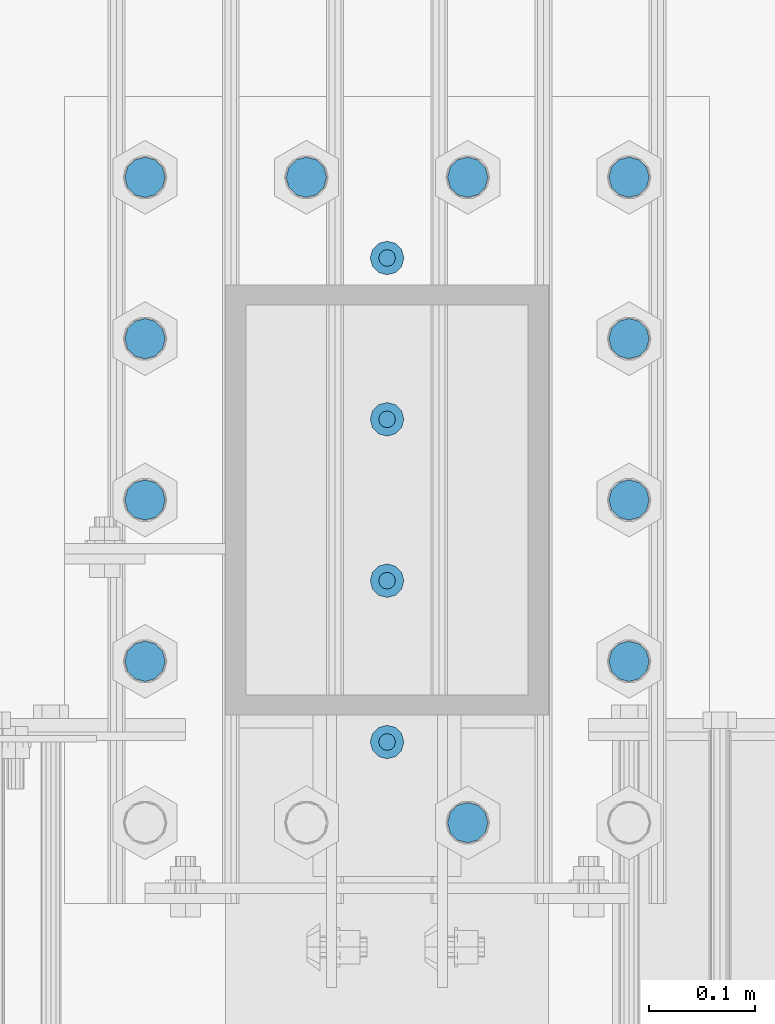
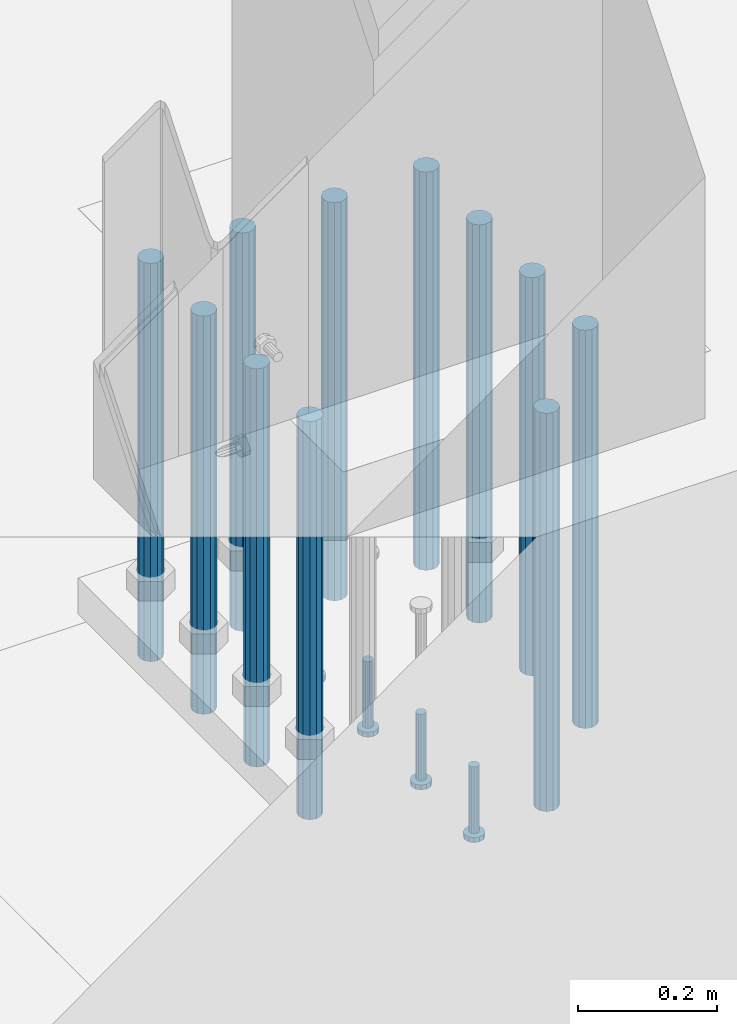
# One storey, part 1086 of 1876: 15 beams, 1 element without a shape of its own.
"""IFC2X3 building model written with IfcOpenShell, lengths in millimetres."""

from ifc_helpers import new_model, si_unit, frame, origin_with_axes, place, context, subcontext, project, spatial, faceted_brep, material, type_object, element, aggregate, save


model = new_model("IFC2X3")

# Units and contexts
model_context = context("Model", 3, precision=1e-05, world=origin_with_axes())
body_context = subcontext(model_context, "Body", "Model", "MODEL_VIEW")
ifc_project = project(units=[si_unit("LENGTHUNIT", "METRE", prefix="MILLI"), si_unit("AREAUNIT", "SQUARE_METRE"), si_unit("VOLUMEUNIT", "CUBIC_METRE"), si_unit("MASSUNIT", "GRAM", prefix="KILO"), si_unit("TIMEUNIT", "SECOND"), si_unit("PLANEANGLEUNIT", "RADIAN"), si_unit("SOLIDANGLEUNIT", "STERADIAN"), si_unit("THERMODYNAMICTEMPERATUREUNIT", "DEGREE_CELSIUS"), si_unit("LUMINOUSINTENSITYUNIT", "LUMEN")], contexts=[model_context])

# Site, building, storey
site_placement = place(None, origin_with_axes())
site = spatial("IfcSite", under=ifc_project, at=site_placement, CompositionType="ELEMENT")
building_placement = place(site_placement, origin_with_axes())
building = spatial("IfcBuilding", under=site, at=building_placement, Name="Undefined", CompositionType="ELEMENT")
storey_placement = place(building_placement, origin_with_axes())
storey = spatial("IfcBuildingStorey", under=building, at=storey_placement, Name="Undefined", CompositionType="ELEMENT", Elevation=0.0)

# Assembly, beams
assembly_placement = place(storey_placement, origin_with_axes())
assembly = element("IfcElementAssembly", 1, at=assembly_placement, inside=storey, Name="PLATE", AssemblyPlace="NOTDEFINED", PredefinedType="RIGID_FRAME")
ifc_material_1 = material(Name="STEEL/F1554-55, S1")
beam_type_1 = type_object("IfcBeamType", PredefinedType="NOTDEFINED")
beam_1_placement = place(assembly_placement, frame((3660.77500610347, -25552.4000091553, -63.4999999999993), z_axis=(-1.0, 0.0, 0.0), x_axis=(0.0, 0.0, -1.0)))
beam_1 = element("IfcBeam", 2, at=beam_1_placement, type_object=beam_type_1, material=ifc_material_1, Name="WELDED ANCHORS", context=body_context, shape_type="Brep", body=[
    faceted_brep([(0.0, -19.0500000000002, 0.0), (0.0, -16.4977839420935, -9.52500000000146), (698.499999999999, -16.4977839420935, -9.52499999999964), (698.499999999999, -19.0499999999993, 0.0), (0.0, -9.52500000000009, -16.4977839420935), (698.499999999999, -9.52500000000146, -16.4977839420935), (0.0, 0.0, -19.05), (698.499999999999, 0.0, -19.0500000000002), (0.0, 9.52500000000009, -16.4977839420935), (698.499999999999, 9.52500000000146, -16.4977839420935), (0.0, 16.4977839420935, -9.52500000000146), (698.499999999999, 16.4977839420935, -9.52499999999964), (-9.09494701772928e-13, 19.05, -1.81898940354586e-12), (698.499999999999, 19.0499999999993, 0.0), (0.0, 16.4977839420935, 9.52500000000146), (698.499999999999, 16.4977839420935, 9.52499999999964), (0.0, 9.52500000000009, 16.4977839420935), (698.499999999999, 9.52500000000146, 16.4977839420935), (0.0, 0.0, 19.0499999999993), (698.499999999999, 0.0, 19.0500000000002), (0.0, -9.52500000000009, 16.4977839420935), (698.499999999999, -9.52500000000146, 16.4977839420935), (0.0, -16.4977839420935, 9.52500000000146), (698.499999999999, -16.4977839420935, 9.52499999999964)], [[[0, 1, 2, 3]], [[1, 4, 5, 2]], [[4, 6, 7, 5]], [[6, 8, 9, 7]], [[8, 10, 11, 9]], [[10, 12, 13, 11]], [[12, 14, 15, 13]], [[14, 16, 17, 15]], [[16, 18, 19, 17]], [[18, 20, 21, 19]], [[20, 22, 23, 21]], [[22, 0, 3, 23]], [[5, 7, 9, 11, 13, 15, 17, 19, 21, 23, 3, 2]], [[22, 20, 18, 16, 14, 12, 10, 8, 6, 4, 1, 0]]]),
])
beam_2_placement = place(assembly_placement, frame((3660.77502441406, -25399.999987793, -63.4999999999993), z_axis=(-1.0, 0.0, 0.0), x_axis=(0.0, 0.0, -1.0)))
beam_2 = element("IfcBeam", 3, at=beam_2_placement, type_object=beam_type_1, material=ifc_material_1, Name="WELDED ANCHORS", context=body_context, shape_type="Brep", body=[
    faceted_brep([(0.0, -19.0500000000002, 0.0), (0.0, -16.4977839420935, -9.52500000000146), (698.499999999999, -16.4977839420935, -9.52499999999964), (698.499999999999, -19.0499999999993, 0.0), (0.0, -9.52500000000009, -16.4977839420935), (698.499999999999, -9.52500000000146, -16.4977839420935), (0.0, 0.0, -19.05), (698.499999999999, 0.0, -19.0500000000002), (0.0, 9.52500000000009, -16.4977839420935), (698.499999999999, 9.52500000000146, -16.4977839420935), (0.0, 16.4977839420935, -9.52500000000146), (698.499999999999, 16.4977839420935, -9.52499999999964), (-9.09494701772928e-13, 19.05, -1.81898940354586e-12), (698.499999999999, 19.0499999999993, 0.0), (0.0, 16.4977839420935, 9.52500000000146), (698.499999999999, 16.4977839420935, 9.52499999999964), (0.0, 9.52500000000009, 16.4977839420935), (698.499999999999, 9.52500000000146, 16.4977839420935), (0.0, 0.0, 19.0499999999993), (698.499999999999, 0.0, 19.0500000000002), (0.0, -9.52500000000009, 16.4977839420935), (698.499999999999, -9.52500000000146, 16.4977839420935), (0.0, -16.4977839420935, 9.52500000000146), (698.499999999999, -16.4977839420935, 9.52499999999964)], [[[0, 1, 2, 3]], [[1, 4, 5, 2]], [[4, 6, 7, 5]], [[6, 8, 9, 7]], [[8, 10, 11, 9]], [[10, 12, 13, 11]], [[12, 14, 15, 13]], [[14, 16, 17, 15]], [[16, 18, 19, 17]], [[18, 20, 21, 19]], [[20, 22, 23, 21]], [[22, 0, 3, 23]], [[5, 7, 9, 11, 13, 15, 17, 19, 21, 23, 3, 2]], [[22, 20, 18, 16, 14, 12, 10, 8, 6, 4, 1, 0]]]),
])
beam_3_placement = place(assembly_placement, frame((3660.77500610347, -25247.5999908447, -63.4999999999993), z_axis=(-1.0, 0.0, 0.0), x_axis=(0.0, 0.0, -1.0)))
beam_3 = element("IfcBeam", 4, at=beam_3_placement, type_object=beam_type_1, material=ifc_material_1, Name="WELDED ANCHORS", context=body_context, shape_type="Brep", body=[
    faceted_brep([(0.0, -19.0500000000002, 0.0), (0.0, -16.4977839420935, -9.52500000000146), (698.499999999999, -16.4977839420935, -9.52499999999964), (698.499999999999, -19.0499999999993, 0.0), (0.0, -9.52500000000009, -16.4977839420935), (698.499999999999, -9.52500000000146, -16.4977839420935), (0.0, 0.0, -19.05), (698.499999999999, 0.0, -19.0500000000002), (0.0, 9.52500000000009, -16.4977839420935), (698.499999999999, 9.52500000000146, -16.4977839420935), (0.0, 16.4977839420935, -9.52500000000146), (698.499999999999, 16.4977839420935, -9.52499999999964), (-9.09494701772928e-13, 19.05, -1.81898940354586e-12), (698.499999999999, 19.0499999999993, 0.0), (0.0, 16.4977839420935, 9.52500000000146), (698.499999999999, 16.4977839420935, 9.52499999999964), (0.0, 9.52500000000009, 16.4977839420935), (698.499999999999, 9.52500000000146, 16.4977839420935), (0.0, 0.0, 19.0499999999993), (698.499999999999, 0.0, 19.0500000000002), (0.0, -9.52500000000009, 16.4977839420935), (698.499999999999, -9.52500000000146, 16.4977839420935), (0.0, -16.4977839420935, 9.52500000000146), (698.499999999999, -16.4977839420935, 9.52499999999964)], [[[0, 1, 2, 3]], [[1, 4, 5, 2]], [[4, 6, 7, 5]], [[6, 8, 9, 7]], [[8, 10, 11, 9]], [[10, 12, 13, 11]], [[12, 14, 15, 13]], [[14, 16, 17, 15]], [[16, 18, 19, 17]], [[18, 20, 21, 19]], [[20, 22, 23, 21]], [[22, 0, 3, 23]], [[5, 7, 9, 11, 13, 15, 17, 19, 21, 23, 3, 2]], [[22, 20, 18, 16, 14, 12, 10, 8, 6, 4, 1, 0]]]),
])
beam_4_placement = place(assembly_placement, frame((4117.9749816894, -25552.4000091553, -63.4999999999993), z_axis=(-1.0, 0.0, 0.0), x_axis=(0.0, 0.0, -1.0)))
beam_4 = element("IfcBeam", 5, at=beam_4_placement, type_object=beam_type_1, material=ifc_material_1, Name="WELDED ANCHORS", context=body_context, shape_type="Brep", body=[
    faceted_brep([(0.0, -19.0500000000002, 0.0), (0.0, -16.4977839420935, -9.52500000000146), (698.499999999999, -16.4977839420935, -9.52499999999964), (698.499999999999, -19.0499999999993, 0.0), (0.0, -9.52500000000009, -16.4977839420935), (698.499999999999, -9.52500000000146, -16.4977839420935), (0.0, 0.0, -19.05), (698.499999999999, 0.0, -19.0500000000002), (0.0, 9.52500000000009, -16.4977839420935), (698.499999999999, 9.52500000000146, -16.4977839420935), (0.0, 16.4977839420935, -9.52500000000146), (698.499999999999, 16.4977839420935, -9.52499999999964), (-9.09494701772928e-13, 19.05, -1.81898940354586e-12), (698.499999999999, 19.0499999999993, 0.0), (0.0, 16.4977839420935, 9.52500000000146), (698.499999999999, 16.4977839420935, 9.52499999999964), (0.0, 9.52500000000009, 16.4977839420935), (698.499999999999, 9.52500000000146, 16.4977839420935), (0.0, 0.0, 19.0499999999993), (698.499999999999, 0.0, 19.0500000000002), (0.0, -9.52500000000009, 16.4977839420935), (698.499999999999, -9.52500000000146, 16.4977839420935), (0.0, -16.4977839420935, 9.52500000000146), (698.499999999999, -16.4977839420935, 9.52499999999964)], [[[0, 1, 2, 3]], [[1, 4, 5, 2]], [[4, 6, 7, 5]], [[6, 8, 9, 7]], [[8, 10, 11, 9]], [[10, 12, 13, 11]], [[12, 14, 15, 13]], [[14, 16, 17, 15]], [[16, 18, 19, 17]], [[18, 20, 21, 19]], [[20, 22, 23, 21]], [[22, 0, 3, 23]], [[5, 7, 9, 11, 13, 15, 17, 19, 21, 23, 3, 2]], [[22, 20, 18, 16, 14, 12, 10, 8, 6, 4, 1, 0]]]),
])
beam_5_placement = place(assembly_placement, frame((4117.975, -25399.999987793, -63.4999999999993), z_axis=(-1.0, 0.0, 0.0), x_axis=(0.0, 0.0, -1.0)))
beam_5 = element("IfcBeam", 6, at=beam_5_placement, type_object=beam_type_1, material=ifc_material_1, Name="WELDED ANCHORS", context=body_context, shape_type="Brep", body=[
    faceted_brep([(0.0, -19.0500000000002, 0.0), (0.0, -16.4977839420935, -9.52500000000146), (698.499999999999, -16.4977839420935, -9.52499999999964), (698.499999999999, -19.0499999999993, 0.0), (0.0, -9.52500000000009, -16.4977839420935), (698.499999999999, -9.52500000000146, -16.4977839420935), (0.0, 0.0, -19.05), (698.499999999999, 0.0, -19.0500000000002), (0.0, 9.52500000000009, -16.4977839420935), (698.499999999999, 9.52500000000146, -16.4977839420935), (0.0, 16.4977839420935, -9.52500000000146), (698.499999999999, 16.4977839420935, -9.52499999999964), (-9.09494701772928e-13, 19.05, -1.81898940354586e-12), (698.499999999999, 19.0499999999993, 0.0), (0.0, 16.4977839420935, 9.52500000000146), (698.499999999999, 16.4977839420935, 9.52499999999964), (0.0, 9.52500000000009, 16.4977839420935), (698.499999999999, 9.52500000000146, 16.4977839420935), (0.0, 0.0, 19.0499999999993), (698.499999999999, 0.0, 19.0500000000002), (0.0, -9.52500000000009, 16.4977839420935), (698.499999999999, -9.52500000000146, 16.4977839420935), (0.0, -16.4977839420935, 9.52500000000146), (698.499999999999, -16.4977839420935, 9.52499999999964)], [[[0, 1, 2, 3]], [[1, 4, 5, 2]], [[4, 6, 7, 5]], [[6, 8, 9, 7]], [[8, 10, 11, 9]], [[10, 12, 13, 11]], [[12, 14, 15, 13]], [[14, 16, 17, 15]], [[16, 18, 19, 17]], [[18, 20, 21, 19]], [[20, 22, 23, 21]], [[22, 0, 3, 23]], [[5, 7, 9, 11, 13, 15, 17, 19, 21, 23, 3, 2]], [[22, 20, 18, 16, 14, 12, 10, 8, 6, 4, 1, 0]]]),
])
beam_6_placement = place(assembly_placement, frame((4117.9749816894, -25247.5999908447, -63.4999999999993), z_axis=(-1.0, 0.0, 0.0), x_axis=(0.0, 0.0, -1.0)))
beam_6 = element("IfcBeam", 7, at=beam_6_placement, type_object=beam_type_1, material=ifc_material_1, Name="WELDED ANCHORS", context=body_context, shape_type="Brep", body=[
    faceted_brep([(0.0, -19.0500000000002, 0.0), (0.0, -16.4977839420935, -9.52500000000146), (698.499999999999, -16.4977839420935, -9.52499999999964), (698.499999999999, -19.0499999999993, 0.0), (0.0, -9.52500000000009, -16.4977839420935), (698.499999999999, -9.52500000000146, -16.4977839420935), (0.0, 0.0, -19.05), (698.499999999999, 0.0, -19.0500000000002), (0.0, 9.52500000000009, -16.4977839420935), (698.499999999999, 9.52500000000146, -16.4977839420935), (0.0, 16.4977839420935, -9.52500000000146), (698.499999999999, 16.4977839420935, -9.52499999999964), (-9.09494701772928e-13, 19.05, -1.81898940354586e-12), (698.499999999999, 19.0499999999993, 0.0), (0.0, 16.4977839420935, 9.52500000000146), (698.499999999999, 16.4977839420935, 9.52499999999964), (0.0, 9.52500000000009, 16.4977839420935), (698.499999999999, 9.52500000000146, 16.4977839420935), (0.0, 0.0, 19.0499999999993), (698.499999999999, 0.0, 19.0500000000002), (0.0, -9.52500000000009, 16.4977839420935), (698.499999999999, -9.52500000000146, 16.4977839420935), (0.0, -16.4977839420935, 9.52500000000146), (698.499999999999, -16.4977839420935, 9.52499999999964)], [[[0, 1, 2, 3]], [[1, 4, 5, 2]], [[4, 6, 7, 5]], [[6, 8, 9, 7]], [[8, 10, 11, 9]], [[10, 12, 13, 11]], [[12, 14, 15, 13]], [[14, 16, 17, 15]], [[16, 18, 19, 17]], [[18, 20, 21, 19]], [[20, 22, 23, 21]], [[22, 0, 3, 23]], [[5, 7, 9, 11, 13, 15, 17, 19, 21, 23, 3, 2]], [[22, 20, 18, 16, 14, 12, 10, 8, 6, 4, 1, 0]]]),
])
beam_7_placement = place(assembly_placement, frame((3965.57500813802, -25095.199987793, -63.4999999999993), z_axis=(-1.0, 0.0, 0.0), x_axis=(0.0, 0.0, -1.0)))
beam_7 = element("IfcBeam", 8, at=beam_7_placement, type_object=beam_type_1, material=ifc_material_1, Name="WELDED ANCHORS", context=body_context, shape_type="Brep", body=[
    faceted_brep([(0.0, -19.0500000000002, 0.0), (0.0, -16.4977839420935, -9.52500000000146), (698.499999999999, -16.4977839420935, -9.52499999999964), (698.499999999999, -19.0499999999993, 0.0), (0.0, -9.52500000000009, -16.4977839420935), (698.499999999999, -9.52500000000146, -16.4977839420935), (0.0, 0.0, -19.05), (698.499999999999, 0.0, -19.0500000000002), (0.0, 9.52500000000009, -16.4977839420935), (698.499999999999, 9.52500000000146, -16.4977839420935), (0.0, 16.4977839420935, -9.52500000000146), (698.499999999999, 16.4977839420935, -9.52499999999964), (-9.09494701772928e-13, 19.05, -1.81898940354586e-12), (698.499999999999, 19.0499999999993, 0.0), (0.0, 16.4977839420935, 9.52500000000146), (698.499999999999, 16.4977839420935, 9.52499999999964), (0.0, 9.52500000000009, 16.4977839420935), (698.499999999999, 9.52500000000146, 16.4977839420935), (0.0, 0.0, 19.0499999999993), (698.499999999999, 0.0, 19.0500000000002), (0.0, -9.52500000000009, 16.4977839420935), (698.499999999999, -9.52500000000146, 16.4977839420935), (0.0, -16.4977839420935, 9.52500000000146), (698.499999999999, -16.4977839420935, 9.52499999999964)], [[[0, 1, 2, 3]], [[1, 4, 5, 2]], [[4, 6, 7, 5]], [[6, 8, 9, 7]], [[8, 10, 11, 9]], [[10, 12, 13, 11]], [[12, 14, 15, 13]], [[14, 16, 17, 15]], [[16, 18, 19, 17]], [[18, 20, 21, 19]], [[20, 22, 23, 21]], [[22, 0, 3, 23]], [[5, 7, 9, 11, 13, 15, 17, 19, 21, 23, 3, 2]], [[22, 20, 18, 16, 14, 12, 10, 8, 6, 4, 1, 0]]]),
])
beam_8_placement = place(assembly_placement, frame((3813.17501627604, -25095.199987793, -63.4999999999993), z_axis=(-1.0, 0.0, 0.0), x_axis=(0.0, 0.0, -1.0)))
beam_8 = element("IfcBeam", 9, at=beam_8_placement, type_object=beam_type_1, material=ifc_material_1, Name="WELDED ANCHORS", context=body_context, shape_type="Brep", body=[
    faceted_brep([(0.0, -19.0500000000002, 0.0), (0.0, -16.4977839420935, -9.52500000000146), (698.499999999999, -16.4977839420935, -9.52499999999964), (698.499999999999, -19.0499999999993, 0.0), (0.0, -9.52500000000009, -16.4977839420935), (698.499999999999, -9.52500000000146, -16.4977839420935), (0.0, 0.0, -19.05), (698.499999999999, 0.0, -19.0500000000002), (0.0, 9.52500000000009, -16.4977839420935), (698.499999999999, 9.52500000000146, -16.4977839420935), (0.0, 16.4977839420935, -9.52500000000146), (698.499999999999, 16.4977839420935, -9.52499999999964), (-9.09494701772928e-13, 19.05, -1.81898940354586e-12), (698.499999999999, 19.0499999999993, 0.0), (0.0, 16.4977839420935, 9.52500000000146), (698.499999999999, 16.4977839420935, 9.52499999999964), (0.0, 9.52500000000009, 16.4977839420935), (698.499999999999, 9.52500000000146, 16.4977839420935), (0.0, 0.0, 19.0499999999993), (698.499999999999, 0.0, 19.0500000000002), (0.0, -9.52500000000009, 16.4977839420935), (698.499999999999, -9.52500000000146, 16.4977839420935), (0.0, -16.4977839420935, 9.52500000000146), (698.499999999999, -16.4977839420935, 9.52499999999964)], [[[0, 1, 2, 3]], [[1, 4, 5, 2]], [[4, 6, 7, 5]], [[6, 8, 9, 7]], [[8, 10, 11, 9]], [[10, 12, 13, 11]], [[12, 14, 15, 13]], [[14, 16, 17, 15]], [[16, 18, 19, 17]], [[18, 20, 21, 19]], [[20, 22, 23, 21]], [[22, 0, 3, 23]], [[5, 7, 9, 11, 13, 15, 17, 19, 21, 23, 3, 2]], [[22, 20, 18, 16, 14, 12, 10, 8, 6, 4, 1, 0]]]),
])
beam_9_placement = place(assembly_placement, frame((3660.77502441406, -25095.199987793, -63.4999999999993), z_axis=(-1.0, 0.0, 0.0), x_axis=(0.0, 0.0, -1.0)))
beam_9 = element("IfcBeam", 10, at=beam_9_placement, type_object=beam_type_1, material=ifc_material_1, Name="WELDED ANCHORS", context=body_context, shape_type="Brep", body=[
    faceted_brep([(0.0, -19.0500000000002, 0.0), (0.0, -16.4977839420935, -9.52500000000146), (698.499999999999, -16.4977839420935, -9.52499999999964), (698.499999999999, -19.0499999999993, 0.0), (0.0, -9.52500000000009, -16.4977839420935), (698.499999999999, -9.52500000000146, -16.4977839420935), (0.0, 0.0, -19.05), (698.499999999999, 0.0, -19.0500000000002), (0.0, 9.52500000000009, -16.4977839420935), (698.499999999999, 9.52500000000146, -16.4977839420935), (0.0, 16.4977839420935, -9.52500000000146), (698.499999999999, 16.4977839420935, -9.52499999999964), (-9.09494701772928e-13, 19.05, -1.81898940354586e-12), (698.499999999999, 19.0499999999993, 0.0), (0.0, 16.4977839420935, 9.52500000000146), (698.499999999999, 16.4977839420935, 9.52499999999964), (0.0, 9.52500000000009, 16.4977839420935), (698.499999999999, 9.52500000000146, 16.4977839420935), (0.0, 0.0, 19.0499999999993), (698.499999999999, 0.0, 19.0500000000002), (0.0, -9.52500000000009, 16.4977839420935), (698.499999999999, -9.52500000000146, 16.4977839420935), (0.0, -16.4977839420935, 9.52500000000146), (698.499999999999, -16.4977839420935, 9.52499999999964)], [[[0, 1, 2, 3]], [[1, 4, 5, 2]], [[4, 6, 7, 5]], [[6, 8, 9, 7]], [[8, 10, 11, 9]], [[10, 12, 13, 11]], [[12, 14, 15, 13]], [[14, 16, 17, 15]], [[16, 18, 19, 17]], [[18, 20, 21, 19]], [[20, 22, 23, 21]], [[22, 0, 3, 23]], [[5, 7, 9, 11, 13, 15, 17, 19, 21, 23, 3, 2]], [[22, 20, 18, 16, 14, 12, 10, 8, 6, 4, 1, 0]]]),
])
beam_10_placement = place(assembly_placement, frame((4117.975, -25095.199987793, -63.4999999999993), z_axis=(-1.0, 0.0, 0.0), x_axis=(0.0, 0.0, -1.0)))
beam_10 = element("IfcBeam", 11, at=beam_10_placement, type_object=beam_type_1, material=ifc_material_1, Name="WELDED ANCHORS", context=body_context, shape_type="Brep", body=[
    faceted_brep([(0.0, -19.0500000000002, 0.0), (0.0, -16.4977839420935, -9.52500000000146), (698.499999999999, -16.4977839420935, -9.52499999999964), (698.499999999999, -19.0499999999993, 0.0), (0.0, -9.52500000000009, -16.4977839420935), (698.499999999999, -9.52500000000146, -16.4977839420935), (0.0, 0.0, -19.05), (698.499999999999, 0.0, -19.0500000000002), (0.0, 9.52500000000009, -16.4977839420935), (698.499999999999, 9.52500000000146, -16.4977839420935), (0.0, 16.4977839420935, -9.52500000000146), (698.499999999999, 16.4977839420935, -9.52499999999964), (-9.09494701772928e-13, 19.05, -1.81898940354586e-12), (698.499999999999, 19.0499999999993, 0.0), (0.0, 16.4977839420935, 9.52500000000146), (698.499999999999, 16.4977839420935, 9.52499999999964), (0.0, 9.52500000000009, 16.4977839420935), (698.499999999999, 9.52500000000146, 16.4977839420935), (0.0, 0.0, 19.0499999999993), (698.499999999999, 0.0, 19.0500000000002), (0.0, -9.52500000000009, 16.4977839420935), (698.499999999999, -9.52500000000146, 16.4977839420935), (0.0, -16.4977839420935, 9.52500000000146), (698.499999999999, -16.4977839420935, 9.52499999999964)], [[[0, 1, 2, 3]], [[1, 4, 5, 2]], [[4, 6, 7, 5]], [[6, 8, 9, 7]], [[8, 10, 11, 9]], [[10, 12, 13, 11]], [[12, 14, 15, 13]], [[14, 16, 17, 15]], [[16, 18, 19, 17]], [[18, 20, 21, 19]], [[20, 22, 23, 21]], [[22, 0, 3, 23]], [[5, 7, 9, 11, 13, 15, 17, 19, 21, 23, 3, 2]], [[22, 20, 18, 16, 14, 12, 10, 8, 6, 4, 1, 0]]]),
])
beam_11_placement = place(assembly_placement, frame((3965.57500813802, -25704.8, -63.4999999999993), z_axis=(-1.0, 0.0, 0.0), x_axis=(0.0, 0.0, -1.0)))
beam_11 = element("IfcBeam", 12, at=beam_11_placement, type_object=beam_type_1, material=ifc_material_1, Name="WELDED ANCHORS", context=body_context, shape_type="Brep", body=[
    faceted_brep([(0.0, -19.0500000000002, 0.0), (0.0, -16.4977839420935, -9.52500000000146), (698.499999999999, -16.4977839420935, -9.52499999999964), (698.499999999999, -19.0499999999993, 0.0), (0.0, -9.52500000000009, -16.4977839420935), (698.499999999999, -9.52500000000146, -16.4977839420935), (0.0, 0.0, -19.05), (698.499999999999, 0.0, -19.0500000000002), (0.0, 9.52500000000009, -16.4977839420935), (698.499999999999, 9.52500000000146, -16.4977839420935), (0.0, 16.4977839420935, -9.52500000000146), (698.499999999999, 16.4977839420935, -9.52499999999964), (-9.09494701772928e-13, 19.05, -1.81898940354586e-12), (698.499999999999, 19.0499999999993, 0.0), (0.0, 16.4977839420935, 9.52500000000146), (698.499999999999, 16.4977839420935, 9.52499999999964), (0.0, 9.52500000000009, 16.4977839420935), (698.499999999999, 9.52500000000146, 16.4977839420935), (0.0, 0.0, 19.0499999999993), (698.499999999999, 0.0, 19.0500000000002), (0.0, -9.52500000000009, 16.4977839420935), (698.499999999999, -9.52500000000146, 16.4977839420935), (0.0, -16.4977839420935, 9.52500000000146), (698.499999999999, -16.4977839420935, 9.52499999999964)], [[[0, 1, 2, 3]], [[1, 4, 5, 2]], [[4, 6, 7, 5]], [[6, 8, 9, 7]], [[8, 10, 11, 9]], [[10, 12, 13, 11]], [[12, 14, 15, 13]], [[14, 16, 17, 15]], [[16, 18, 19, 17]], [[18, 20, 21, 19]], [[20, 22, 23, 21]], [[22, 0, 3, 23]], [[5, 7, 9, 11, 13, 15, 17, 19, 21, 23, 3, 2]], [[22, 20, 18, 16, 14, 12, 10, 8, 6, 4, 1, 0]]]),
])
ifc_material_2 = material(Name="STEEL/A108")
beam_type_2 = type_object("IfcBeamType", Name="5/8-DIA_HEADED ANCHOR STUD", PredefinedType="NOTDEFINED")
beam_12_placement = place(assembly_placement, frame((3889.37501220698, -25628.6000061035, -711.199999999997), z_axis=(0.0, -1.0, 0.0), x_axis=(0.0, 0.0, -1.0)))
beam_12 = element("IfcBeam", 13, at=beam_12_placement, type_object=beam_type_2, material=ifc_material_2, Name="HEADED ANCHOR STUD", ObjectType="5/8-DIA_HEADED ANCHOR STUD", context=body_context, shape_type="Brep", body=[
    faceted_brep([(0.0, -7.94000005722046, 0.0), (0.0, -6.86999988555908, -3.97000002861023), (116.84, -6.86999988555908, -3.97000002861023), (116.84, -7.94000005722046, 0.0), (0.0, -3.97000002861023, -6.86999988555908), (116.84, -3.97000002861023, -6.86999988555908), (0.0, 0.0, -7.94000005722046), (116.84, 0.0, -7.94000005722046), (0.0, 3.97000002861023, -6.86999988555908), (116.84, 3.97000002861023, -6.86999988555908), (0.0, 6.86999988555908, -3.97000002861023), (116.84, 6.86999988555908, -3.97000002861023), (0.0, 7.94000005722046, 0.0), (116.84, 7.94000005722046, 0.0), (0.0, 6.86999988555908, 3.97000002861023), (116.84, 6.86999988555908, 3.97000002861023), (0.0, 3.97000002861023, 6.86999988555908), (116.84, 3.97000002861023, 6.86999988555908), (0.0, 0.0, 7.94000005722046), (116.84, 0.0, 7.94000005722046), (0.0, -3.97000002861023, 6.86999988555908), (116.84, -3.97000002861023, 6.86999988555908), (0.0, -6.86999988555908, 3.97000002861023), (116.84, -6.86999988555908, 3.97000002861023), (118.11, -13.75, -7.94000005722046), (118.11, -15.8800001144409, 0.0), (118.11, -7.94000005722046, -13.75), (118.11, 0.0, -15.8800001144409), (118.11, 7.94000005722046, -13.75), (118.11, 13.75, -7.94000005722046), (118.11, 15.8800001144409, 0.0), (118.11, 13.75, 7.94000005722046), (118.11, 7.94000005722046, 13.75), (118.11, 0.0, 15.8800001144409), (118.11, -7.94000005722046, 13.75), (118.11, -13.75, 7.94000005722046), (127.0, -13.75, -7.94000005722046), (127.0, -15.8800001144409, 0.0), (127.0, -7.94000005722046, -13.75), (127.0, 0.0, -15.8800001144409), (127.0, 7.94000005722046, -13.75), (127.0, 13.75, -7.94000005722046), (127.0, 15.8800001144409, 0.0), (127.0, 13.75, 7.94000005722046), (127.0, 7.94000005722046, 13.75), (127.0, 0.0, 15.8800001144409), (127.0, -7.94000005722046, 13.75), (127.0, -13.75, 7.94000005722046)], [[[0, 1, 2, 3]], [[1, 4, 5, 2]], [[4, 6, 7, 5]], [[6, 8, 9, 7]], [[8, 10, 11, 9]], [[10, 12, 13, 11]], [[12, 14, 15, 13]], [[14, 16, 17, 15]], [[16, 18, 19, 17]], [[18, 20, 21, 19]], [[20, 22, 23, 21]], [[22, 0, 3, 23]], [[22, 20, 18, 16, 14, 12, 10, 8, 6, 4, 1, 0]], [[3, 2, 24, 25]], [[2, 5, 26, 24]], [[5, 7, 27, 26]], [[7, 9, 28, 27]], [[9, 11, 29, 28]], [[11, 13, 30, 29]], [[13, 15, 31, 30]], [[15, 17, 32, 31]], [[17, 19, 33, 32]], [[19, 21, 34, 33]], [[21, 23, 35, 34]], [[23, 3, 25, 35]], [[25, 24, 36, 37]], [[24, 26, 38, 36]], [[26, 27, 39, 38]], [[27, 28, 40, 39]], [[28, 29, 41, 40]], [[29, 30, 42, 41]], [[30, 31, 43, 42]], [[31, 32, 44, 43]], [[32, 33, 45, 44]], [[33, 34, 46, 45]], [[34, 35, 47, 46]], [[35, 25, 37, 47]], [[38, 39, 40, 41, 42, 43, 44, 45, 46, 47, 37, 36]]]),
])
beam_13_placement = place(assembly_placement, frame((3889.375, -25476.200012207, -711.199999999997), z_axis=(0.0, -1.0, 0.0), x_axis=(0.0, 0.0, -1.0)))
beam_13 = element("IfcBeam", 14, at=beam_13_placement, type_object=beam_type_2, material=ifc_material_2, Name="HEADED ANCHOR STUD", ObjectType="5/8-DIA_HEADED ANCHOR STUD", context=body_context, shape_type="Brep", body=[
    faceted_brep([(0.0, -7.94000005722046, 0.0), (0.0, -6.86999988555908, -3.97000002861023), (116.84, -6.86999988555908, -3.97000002861023), (116.84, -7.94000005722046, 0.0), (0.0, -3.97000002861023, -6.86999988555908), (116.84, -3.97000002861023, -6.86999988555908), (0.0, 0.0, -7.94000005722046), (116.84, 0.0, -7.94000005722046), (0.0, 3.97000002861023, -6.86999988555908), (116.84, 3.97000002861023, -6.86999988555908), (0.0, 6.86999988555908, -3.97000002861023), (116.84, 6.86999988555908, -3.97000002861023), (0.0, 7.94000005722046, 0.0), (116.84, 7.94000005722046, 0.0), (0.0, 6.86999988555908, 3.97000002861023), (116.84, 6.86999988555908, 3.97000002861023), (0.0, 3.97000002861023, 6.86999988555908), (116.84, 3.97000002861023, 6.86999988555908), (0.0, 0.0, 7.94000005722046), (116.84, 0.0, 7.94000005722046), (0.0, -3.97000002861023, 6.86999988555908), (116.84, -3.97000002861023, 6.86999988555908), (0.0, -6.86999988555908, 3.97000002861023), (116.84, -6.86999988555908, 3.97000002861023), (118.11, -13.75, -7.94000005722046), (118.11, -15.8800001144409, 0.0), (118.11, -7.94000005722046, -13.75), (118.11, 0.0, -15.8800001144409), (118.11, 7.94000005722046, -13.75), (118.11, 13.75, -7.94000005722046), (118.11, 15.8800001144409, 0.0), (118.11, 13.75, 7.94000005722046), (118.11, 7.94000005722046, 13.75), (118.11, 0.0, 15.8800001144409), (118.11, -7.94000005722046, 13.75), (118.11, -13.75, 7.94000005722046), (127.0, -13.75, -7.94000005722046), (127.0, -15.8800001144409, 0.0), (127.0, -7.94000005722046, -13.75), (127.0, 0.0, -15.8800001144409), (127.0, 7.94000005722046, -13.75), (127.0, 13.75, -7.94000005722046), (127.0, 15.8800001144409, 0.0), (127.0, 13.75, 7.94000005722046), (127.0, 7.94000005722046, 13.75), (127.0, 0.0, 15.8800001144409), (127.0, -7.94000005722046, 13.75), (127.0, -13.75, 7.94000005722046)], [[[0, 1, 2, 3]], [[1, 4, 5, 2]], [[4, 6, 7, 5]], [[6, 8, 9, 7]], [[8, 10, 11, 9]], [[10, 12, 13, 11]], [[12, 14, 15, 13]], [[14, 16, 17, 15]], [[16, 18, 19, 17]], [[18, 20, 21, 19]], [[20, 22, 23, 21]], [[22, 0, 3, 23]], [[22, 20, 18, 16, 14, 12, 10, 8, 6, 4, 1, 0]], [[3, 2, 24, 25]], [[2, 5, 26, 24]], [[5, 7, 27, 26]], [[7, 9, 28, 27]], [[9, 11, 29, 28]], [[11, 13, 30, 29]], [[13, 15, 31, 30]], [[15, 17, 32, 31]], [[17, 19, 33, 32]], [[19, 21, 34, 33]], [[21, 23, 35, 34]], [[23, 3, 25, 35]], [[25, 24, 36, 37]], [[24, 26, 38, 36]], [[26, 27, 39, 38]], [[27, 28, 40, 39]], [[28, 29, 41, 40]], [[29, 30, 42, 41]], [[30, 31, 43, 42]], [[31, 32, 44, 43]], [[32, 33, 45, 44]], [[33, 34, 46, 45]], [[34, 35, 47, 46]], [[35, 25, 37, 47]], [[38, 39, 40, 41, 42, 43, 44, 45, 46, 47, 37, 36]]]),
])
beam_14_placement = place(assembly_placement, frame((3889.375, -25323.8000152588, -711.199999999997), z_axis=(0.0, -1.0, 0.0), x_axis=(0.0, 0.0, -1.0)))
beam_14 = element("IfcBeam", 15, at=beam_14_placement, type_object=beam_type_2, material=ifc_material_2, Name="HEADED ANCHOR STUD", ObjectType="5/8-DIA_HEADED ANCHOR STUD", context=body_context, shape_type="Brep", body=[
    faceted_brep([(0.0, -7.94000005722046, 0.0), (0.0, -6.86999988555908, -3.97000002861023), (116.84, -6.86999988555908, -3.97000002861023), (116.84, -7.94000005722046, 0.0), (0.0, -3.97000002861023, -6.86999988555908), (116.84, -3.97000002861023, -6.86999988555908), (0.0, 0.0, -7.94000005722046), (116.84, 0.0, -7.94000005722046), (0.0, 3.97000002861023, -6.86999988555908), (116.84, 3.97000002861023, -6.86999988555908), (0.0, 6.86999988555908, -3.97000002861023), (116.84, 6.86999988555908, -3.97000002861023), (0.0, 7.94000005722046, 0.0), (116.84, 7.94000005722046, 0.0), (0.0, 6.86999988555908, 3.97000002861023), (116.84, 6.86999988555908, 3.97000002861023), (0.0, 3.97000002861023, 6.86999988555908), (116.84, 3.97000002861023, 6.86999988555908), (0.0, 0.0, 7.94000005722046), (116.84, 0.0, 7.94000005722046), (0.0, -3.97000002861023, 6.86999988555908), (116.84, -3.97000002861023, 6.86999988555908), (0.0, -6.86999988555908, 3.97000002861023), (116.84, -6.86999988555908, 3.97000002861023), (118.11, -13.75, -7.94000005722046), (118.11, -15.8800001144409, 0.0), (118.11, -7.94000005722046, -13.75), (118.11, 0.0, -15.8800001144409), (118.11, 7.94000005722046, -13.75), (118.11, 13.75, -7.94000005722046), (118.11, 15.8800001144409, 0.0), (118.11, 13.75, 7.94000005722046), (118.11, 7.94000005722046, 13.75), (118.11, 0.0, 15.8800001144409), (118.11, -7.94000005722046, 13.75), (118.11, -13.75, 7.94000005722046), (127.0, -13.75, -7.94000005722046), (127.0, -15.8800001144409, 0.0), (127.0, -7.94000005722046, -13.75), (127.0, 0.0, -15.8800001144409), (127.0, 7.94000005722046, -13.75), (127.0, 13.75, -7.94000005722046), (127.0, 15.8800001144409, 0.0), (127.0, 13.75, 7.94000005722046), (127.0, 7.94000005722046, 13.75), (127.0, 0.0, 15.8800001144409), (127.0, -7.94000005722046, 13.75), (127.0, -13.75, 7.94000005722046)], [[[0, 1, 2, 3]], [[1, 4, 5, 2]], [[4, 6, 7, 5]], [[6, 8, 9, 7]], [[8, 10, 11, 9]], [[10, 12, 13, 11]], [[12, 14, 15, 13]], [[14, 16, 17, 15]], [[16, 18, 19, 17]], [[18, 20, 21, 19]], [[20, 22, 23, 21]], [[22, 0, 3, 23]], [[22, 20, 18, 16, 14, 12, 10, 8, 6, 4, 1, 0]], [[3, 2, 24, 25]], [[2, 5, 26, 24]], [[5, 7, 27, 26]], [[7, 9, 28, 27]], [[9, 11, 29, 28]], [[11, 13, 30, 29]], [[13, 15, 31, 30]], [[15, 17, 32, 31]], [[17, 19, 33, 32]], [[19, 21, 34, 33]], [[21, 23, 35, 34]], [[23, 3, 25, 35]], [[25, 24, 36, 37]], [[24, 26, 38, 36]], [[26, 27, 39, 38]], [[27, 28, 40, 39]], [[28, 29, 41, 40]], [[29, 30, 42, 41]], [[30, 31, 43, 42]], [[31, 32, 44, 43]], [[32, 33, 45, 44]], [[33, 34, 46, 45]], [[34, 35, 47, 46]], [[35, 25, 37, 47]], [[38, 39, 40, 41, 42, 43, 44, 45, 46, 47, 37, 36]]]),
])
beam_15_placement = place(assembly_placement, frame((3889.37501220698, -25171.4000091553, -711.199999999997), z_axis=(0.0, -1.0, 0.0), x_axis=(0.0, 0.0, -1.0)))
beam_15 = element("IfcBeam", 16, at=beam_15_placement, type_object=beam_type_2, material=ifc_material_2, Name="HEADED ANCHOR STUD", ObjectType="5/8-DIA_HEADED ANCHOR STUD", context=body_context, shape_type="Brep", body=[
    faceted_brep([(0.0, -7.94000005722046, 0.0), (0.0, -6.86999988555908, -3.97000002861023), (116.84, -6.86999988555908, -3.97000002861023), (116.84, -7.94000005722046, 0.0), (0.0, -3.97000002861023, -6.86999988555908), (116.84, -3.97000002861023, -6.86999988555908), (0.0, 0.0, -7.94000005722046), (116.84, 0.0, -7.94000005722046), (0.0, 3.97000002861023, -6.86999988555908), (116.84, 3.97000002861023, -6.86999988555908), (0.0, 6.86999988555908, -3.97000002861023), (116.84, 6.86999988555908, -3.97000002861023), (0.0, 7.94000005722046, 0.0), (116.84, 7.94000005722046, 0.0), (0.0, 6.86999988555908, 3.97000002861023), (116.84, 6.86999988555908, 3.97000002861023), (0.0, 3.97000002861023, 6.86999988555908), (116.84, 3.97000002861023, 6.86999988555908), (0.0, 0.0, 7.94000005722046), (116.84, 0.0, 7.94000005722046), (0.0, -3.97000002861023, 6.86999988555908), (116.84, -3.97000002861023, 6.86999988555908), (0.0, -6.86999988555908, 3.97000002861023), (116.84, -6.86999988555908, 3.97000002861023), (118.11, -13.75, -7.94000005722046), (118.11, -15.8800001144409, 0.0), (118.11, -7.94000005722046, -13.75), (118.11, 0.0, -15.8800001144409), (118.11, 7.94000005722046, -13.75), (118.11, 13.75, -7.94000005722046), (118.11, 15.8800001144409, 0.0), (118.11, 13.75, 7.94000005722046), (118.11, 7.94000005722046, 13.75), (118.11, 0.0, 15.8800001144409), (118.11, -7.94000005722046, 13.75), (118.11, -13.75, 7.94000005722046), (127.0, -13.75, -7.94000005722046), (127.0, -15.8800001144409, 0.0), (127.0, -7.94000005722046, -13.75), (127.0, 0.0, -15.8800001144409), (127.0, 7.94000005722046, -13.75), (127.0, 13.75, -7.94000005722046), (127.0, 15.8800001144409, 0.0), (127.0, 13.75, 7.94000005722046), (127.0, 7.94000005722046, 13.75), (127.0, 0.0, 15.8800001144409), (127.0, -7.94000005722046, 13.75), (127.0, -13.75, 7.94000005722046)], [[[0, 1, 2, 3]], [[1, 4, 5, 2]], [[4, 6, 7, 5]], [[6, 8, 9, 7]], [[8, 10, 11, 9]], [[10, 12, 13, 11]], [[12, 14, 15, 13]], [[14, 16, 17, 15]], [[16, 18, 19, 17]], [[18, 20, 21, 19]], [[20, 22, 23, 21]], [[22, 0, 3, 23]], [[22, 20, 18, 16, 14, 12, 10, 8, 6, 4, 1, 0]], [[3, 2, 24, 25]], [[2, 5, 26, 24]], [[5, 7, 27, 26]], [[7, 9, 28, 27]], [[9, 11, 29, 28]], [[11, 13, 30, 29]], [[13, 15, 31, 30]], [[15, 17, 32, 31]], [[17, 19, 33, 32]], [[19, 21, 34, 33]], [[21, 23, 35, 34]], [[23, 3, 25, 35]], [[25, 24, 36, 37]], [[24, 26, 38, 36]], [[26, 27, 39, 38]], [[27, 28, 40, 39]], [[28, 29, 41, 40]], [[29, 30, 42, 41]], [[30, 31, 43, 42]], [[31, 32, 44, 43]], [[32, 33, 45, 44]], [[33, 34, 46, 45]], [[34, 35, 47, 46]], [[35, 25, 37, 47]], [[38, 39, 40, 41, 42, 43, 44, 45, 46, 47, 37, 36]]]),
])
aggregate(assembly, [beam_12, beam_13, beam_14, beam_15, beam_1, beam_2, beam_3, beam_4, beam_5, beam_6, beam_7, beam_8, beam_9, beam_10, beam_11])

save(model, "model.ifc")
